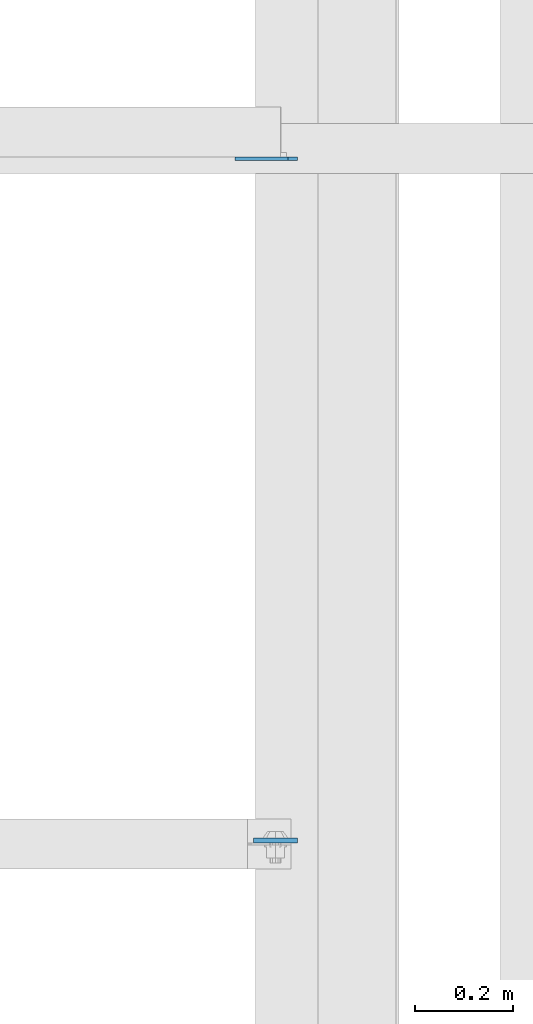
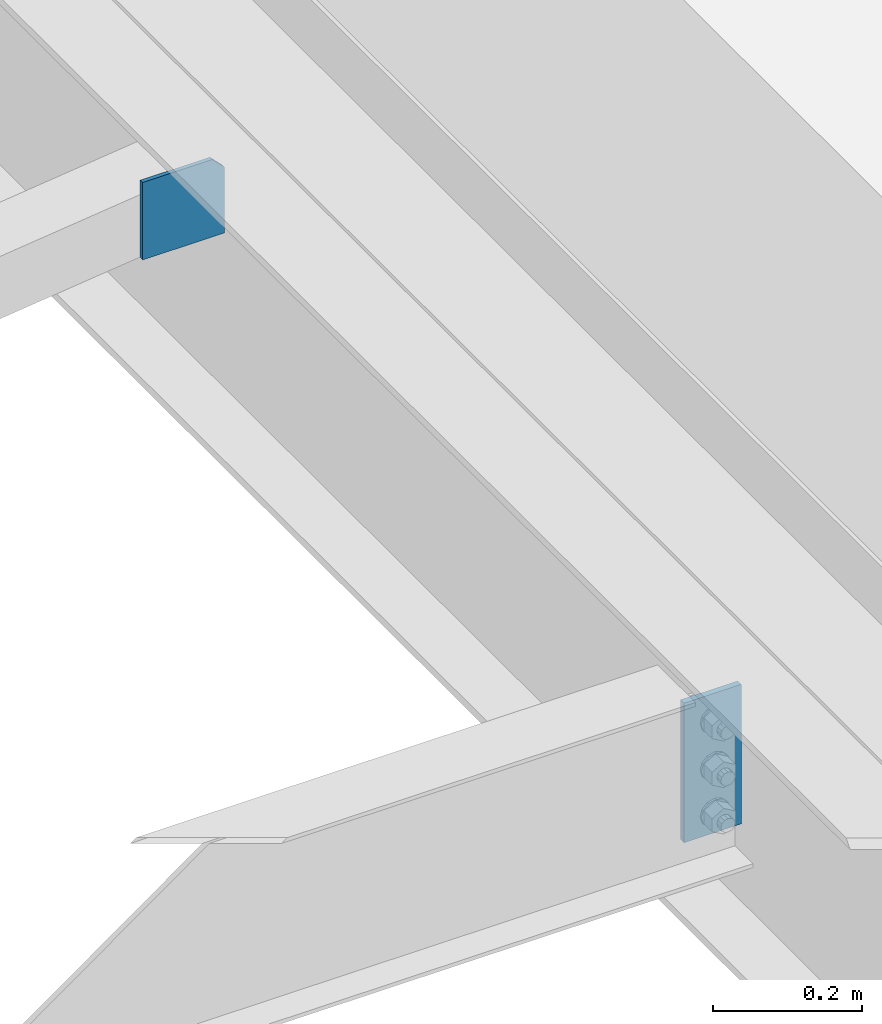
# One storey, part 3350 of 3843: 2 plates, 1 element without a shape of its own.
"""IFC2X3 building model written with IfcOpenShell, lengths in millimetres."""

from ifc_helpers import new_model, si_unit, frame, origin_with_axes, place, context, subcontext, project, spatial, faceted_brep, material, type_object, element, aggregate, save


model = new_model("IFC2X3")

# Units and contexts
model_context = context("Model", 3, precision=1e-05, world=origin_with_axes())
body_context = subcontext(model_context, "Body", "Model", "MODEL_VIEW")
ifc_project = project(units=[si_unit("LENGTHUNIT", "METRE", prefix="MILLI"), si_unit("AREAUNIT", "SQUARE_METRE"), si_unit("VOLUMEUNIT", "CUBIC_METRE"), si_unit("MASSUNIT", "GRAM", prefix="KILO"), si_unit("TIMEUNIT", "SECOND"), si_unit("PLANEANGLEUNIT", "RADIAN"), si_unit("SOLIDANGLEUNIT", "STERADIAN"), si_unit("THERMODYNAMICTEMPERATUREUNIT", "DEGREE_CELSIUS"), si_unit("LUMINOUSINTENSITYUNIT", "LUMEN")], contexts=[model_context])

# Site, building, storey
site_placement = place(None, origin_with_axes())
site = spatial("IfcSite", under=ifc_project, at=site_placement, CompositionType="ELEMENT")
building_placement = place(site_placement, origin_with_axes())
building = spatial("IfcBuilding", under=site, at=building_placement, Name="Undefined", CompositionType="ELEMENT")
storey_placement = place(building_placement, origin_with_axes())
storey = spatial("IfcBuildingStorey", under=building, at=storey_placement, Name="Undefined", CompositionType="ELEMENT", Elevation=0.0)

# Assembly, plates
assembly_placement = place(storey_placement, origin_with_axes())
assembly = element("IfcElementAssembly", 1, at=assembly_placement, inside=storey, Name="BEAM", AssemblyPlace="NOTDEFINED", PredefinedType="RIGID_FRAME")
ifc_material = material(Name="STEEL/A572-50")
plate_type_1 = type_object("IfcPlateType", PredefinedType="NOTDEFINED")
plate_1_placement = place(assembly_placement, frame((38816.75625, 64493.378126, 33997.9), z_axis=(-1.0, 0.0, 0.0), x_axis=(0.0, 0.0, -1.0)))
plate_1 = element("IfcPlate", 2, at=plate_1_placement, type_object=plate_type_1, material=ifc_material, Name="PLATE", context=body_context, shape_type="Brep", body=[
    faceted_brep([(0.0, -4.76249999999709, 0.0), (0.0, -4.76249999999709, 88.9000015258789), (0.0, 4.76249999999709, 88.9000015258789), (0.0, 4.76249999999709, 0.0), (228.600006102781, -4.7625000004191, 88.9000015257589), (228.600006102781, 4.76249999954598, 88.9000015257443), (228.600006103079, -4.7625000004482, 7.27595761418343e-12), (228.600006103079, 4.76249999954598, -7.27595761418343e-12)], [[[0, 1, 2, 3]], [[1, 4, 5, 2]], [[4, 6, 7, 5]], [[6, 0, 3, 7]], [[5, 7, 3, 2]], [[6, 4, 1, 0]]]),
])
plate_type_2 = type_object("IfcPlateType", PredefinedType="NOTDEFINED")
plate_2_placement = place(assembly_placement, frame((38816.75625, 65879.067188, 33896.3), z_axis=(0.0, 0.0, 1.0), x_axis=(-1.0, 0.0, 0.0)))
plate_2 = element("IfcPlate", 3, at=plate_2_placement, type_object=plate_type_2, material=ifc_material, Name="PLATE", context=body_context, shape_type="Brep", body=[
    faceted_brep([(0.0, -3.17499999999927, 0.0), (0.0, -3.17500000000291, 107.950000000004), (0.0, 3.17500000000291, 107.950000000004), (0.0, 3.17499999999927, 0.0), (19.0500000000029, -3.17500000000291, 127.0), (19.0500000000029, 3.17500000000291, 127.0), (127.0, -3.17500000000291, 127.0), (127.0, 3.17500000000291, 127.0), (127.0, -3.17500000000291, 0.0), (127.0, 3.17500000000291, 0.0)], [[[0, 1, 2, 3]], [[1, 4, 5, 2]], [[4, 6, 7, 5]], [[6, 8, 9, 7]], [[8, 0, 3, 9]], [[5, 7, 9, 3, 2]], [[8, 6, 4, 1, 0]]]),
])
aggregate(assembly, [plate_2, plate_1])

save(model, "model.ifc")
